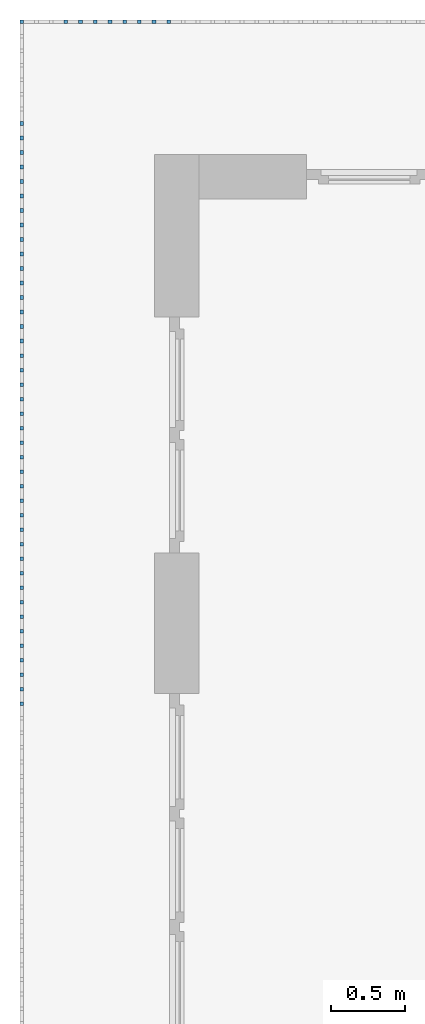
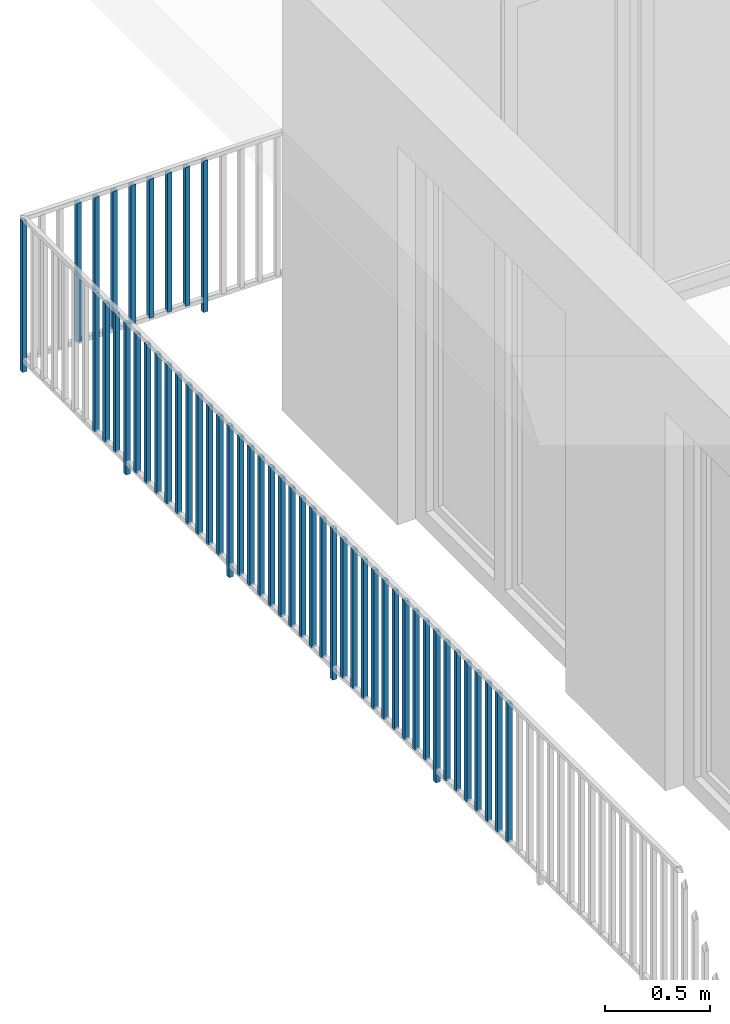
# One storey, part 47 of 54: 50 building element parts, 1 element without a shape of its own.
"""IFC4 building model written with IfcOpenShell, lengths in metres."""

from ifc_helpers import new_model, entity, si_unit, converted_unit, derived_unit, direction, frame, origin_with_axes, place, context, subcontext, project, spatial, polygons, material, type_object, element, aggregate, save


model = new_model("IFC4")

# Units and contexts
model_context = context("Model", 3, precision=1e-05, world=origin_with_axes(), true_north=direction((0.0, 1.0)))
body_context = subcontext(model_context, "Body", "Model", "MODEL_VIEW")
ifc_project = project(units=[si_unit("LENGTHUNIT", "METRE"), si_unit("AREAUNIT", "SQUARE_METRE"), si_unit("VOLUMEUNIT", "CUBIC_METRE"), converted_unit("PLANEANGLEUNIT", "DEGREE", entity("IfcPlaneAngleMeasure", 0.0174532925199), si_unit("PLANEANGLEUNIT", "RADIAN"), dimensions=[0, 0, 0, 0, 0, 0, 0]), converted_unit("TIMEUNIT", "Year", entity("IfcTimeMeasure", 31556926.0), si_unit("TIMEUNIT", "SECOND"), dimensions=[0, 0, 1, 0, 0, 0, 0]), si_unit("MASSUNIT", "GRAM", prefix="KILO"), si_unit("THERMODYNAMICTEMPERATUREUNIT", "DEGREE_CELSIUS"), si_unit("LUMINOUSINTENSITYUNIT", "LUMEN"), si_unit("ENERGYUNIT", "JOULE", prefix="MEGA"), derived_unit("THERMALCONDUCTANCEUNIT", [(si_unit("POWERUNIT", "WATT"), 1), (si_unit("LENGTHUNIT", "METRE"), -1), (si_unit("THERMODYNAMICTEMPERATUREUNIT", "KELVIN"), -1)]), derived_unit("SPECIFICHEATCAPACITYUNIT", [(si_unit("ENERGYUNIT", "JOULE"), 1), (si_unit("MASSUNIT", "GRAM", prefix="KILO"), -1), (si_unit("THERMODYNAMICTEMPERATUREUNIT", "KELVIN"), -1)]), derived_unit("MASSDENSITYUNIT", [(si_unit("MASSUNIT", "GRAM", prefix="KILO"), 1), (si_unit("VOLUMEUNIT", "CUBIC_METRE"), -1)])], contexts=[model_context])

# Site, building, storey, space
site_placement = place(None, origin_with_axes())
site = spatial("IfcSite", under=ifc_project, at=site_placement, CompositionType="ELEMENT")
building_placement = place(site_placement, origin_with_axes())
building = spatial("IfcBuilding", under=site, at=building_placement, CompositionType="ELEMENT")
storey_placement = place(building_placement, frame((0.0, 0.0, 6.29), z_axis=(0.0, 0.0, 1.0), x_axis=(1.0, 0.0, 0.0)))
storey = spatial("IfcBuildingStorey", under=building, at=storey_placement, Name="2. Geschoss", CompositionType="ELEMENT", Elevation=6.29)
space_placement = place(storey_placement, frame((10.2378006196, 9.82118769833, 0.0), z_axis=(0.0, 0.0, 1.0), x_axis=(-1.0, 0.0, 0.0)))
space = spatial("IfcSpace", under=storey, at=space_placement, CompositionType="ELEMENT", PredefinedType="EXTERNAL")

# Railing, building element parts
railing_type = type_object("IfcRailingType", PredefinedType="NOTDEFINED")
railing_placement = place(space_placement, frame((0.0, -7.06315681498e-08, 0.0), z_axis=(0.0, 0.0, 1.0), x_axis=(-1.0, 0.0, 0.0)))
railing = element("IfcRailing", 1, at=railing_placement, inside=space, type_object=railing_type, PredefinedType="NOTDEFINED")
ifc_material = material()
building_element_part_1_placement = place(railing_placement, origin_with_axes())
building_element_part_1 = element("IfcBuildingElementPart", 2, at=building_element_part_1_placement, material=ifc_material, PredefinedType="NOTDEFINED", context=body_context, shape_type="Tessellation", body=[
    polygons([(-22.8925, 0.0125, 0.0), (-22.8925, -0.0125, 0.0), (-22.8925, -0.0125, 0.88), (-22.8925, 0.0125, 0.88), (-22.8675, 0.0125, 0.0), (-22.8675, -0.0125, 0.0), (-22.8675, -0.0125, 0.88), (-22.8675, 0.0125, 0.88)], [[[1, 2, 3, 4]], [[1, 5, 6, 2]], [[2, 6, 7, 3]], [[4, 3, 7, 8]], [[5, 1, 4, 8]], [[6, 5, 8, 7]]], closed=True),
])
building_element_part_2_placement = place(railing_placement, origin_with_axes())
building_element_part_2 = element("IfcBuildingElementPart", 3, at=building_element_part_2_placement, material=ifc_material, PredefinedType="NOTDEFINED", context=body_context, shape_type="Tessellation", body=[
    polygons([(-21.8977173913, 0.0125, 0.0), (-21.8977173913, -0.0125, 0.0), (-21.8977173913, -0.0125, 0.88), (-21.8977173913, 0.0125, 0.88), (-21.8727173913, 0.0125, 0.0), (-21.8727173913, -0.0125, 0.0), (-21.8727173913, -0.0125, 0.88), (-21.8727173913, 0.0125, 0.88)], [[[1, 2, 3, 4]], [[1, 5, 6, 2]], [[2, 6, 7, 3]], [[4, 3, 7, 8]], [[5, 1, 4, 8]], [[6, 5, 8, 7]]], closed=True),
])
building_element_part_3_placement = place(railing_placement, origin_with_axes())
building_element_part_3 = element("IfcBuildingElementPart", 4, at=building_element_part_3_placement, material=ifc_material, PredefinedType="NOTDEFINED", context=body_context, shape_type="Tessellation", body=[
    polygons([(-21.9971956522, 0.0125, 0.07), (-21.9971956522, -0.0125, 0.07), (-21.9971956522, -0.0125, 0.8775), (-21.9971956522, 0.0125, 0.8775), (-21.9721956522, 0.0125, 0.07), (-21.9721956522, -0.0125, 0.07), (-21.9721956522, -0.0125, 0.8775), (-21.9721956522, 0.0125, 0.8775)], [[[1, 2, 3, 4]], [[1, 5, 6, 2]], [[2, 6, 7, 3]], [[4, 3, 7, 8]], [[5, 1, 4, 8]], [[6, 5, 8, 7]]], closed=True),
])
building_element_part_4_placement = place(railing_placement, origin_with_axes())
building_element_part_4 = element("IfcBuildingElementPart", 5, at=building_element_part_4_placement, material=ifc_material, PredefinedType="NOTDEFINED", context=body_context, shape_type="Tessellation", body=[
    polygons([(-22.096673913, 0.0125, 0.07), (-22.096673913, -0.0125, 0.07), (-22.096673913, -0.0125, 0.8775), (-22.096673913, 0.0125, 0.8775), (-22.071673913, 0.0125, 0.07), (-22.071673913, -0.0125, 0.07), (-22.071673913, -0.0125, 0.8775), (-22.071673913, 0.0125, 0.8775)], [[[1, 2, 3, 4]], [[1, 5, 6, 2]], [[2, 6, 7, 3]], [[4, 3, 7, 8]], [[5, 1, 4, 8]], [[6, 5, 8, 7]]], closed=True),
])
building_element_part_5_placement = place(railing_placement, origin_with_axes())
building_element_part_5 = element("IfcBuildingElementPart", 6, at=building_element_part_5_placement, material=ifc_material, PredefinedType="NOTDEFINED", context=body_context, shape_type="Tessellation", body=[
    polygons([(-22.1961521739, 0.0125, 0.07), (-22.1961521739, -0.0125, 0.07), (-22.1961521739, -0.0125, 0.8775), (-22.1961521739, 0.0125, 0.8775), (-22.1711521739, 0.0125, 0.07), (-22.1711521739, -0.0125, 0.07), (-22.1711521739, -0.0125, 0.8775), (-22.1711521739, 0.0125, 0.8775)], [[[1, 2, 3, 4]], [[1, 5, 6, 2]], [[2, 6, 7, 3]], [[4, 3, 7, 8]], [[5, 1, 4, 8]], [[6, 5, 8, 7]]], closed=True),
])
building_element_part_6_placement = place(railing_placement, origin_with_axes())
building_element_part_6 = element("IfcBuildingElementPart", 7, at=building_element_part_6_placement, material=ifc_material, PredefinedType="NOTDEFINED", context=body_context, shape_type="Tessellation", body=[
    polygons([(-22.2956304348, 0.0125, 0.07), (-22.2956304348, -0.0125, 0.07), (-22.2956304348, -0.0125, 0.8775), (-22.2956304348, 0.0125, 0.8775), (-22.2706304348, 0.0125, 0.07), (-22.2706304348, -0.0125, 0.07), (-22.2706304348, -0.0125, 0.8775), (-22.2706304348, 0.0125, 0.8775)], [[[1, 2, 3, 4]], [[1, 5, 6, 2]], [[2, 6, 7, 3]], [[4, 3, 7, 8]], [[5, 1, 4, 8]], [[6, 5, 8, 7]]], closed=True),
])
building_element_part_7_placement = place(railing_placement, origin_with_axes())
building_element_part_7 = element("IfcBuildingElementPart", 8, at=building_element_part_7_placement, material=ifc_material, PredefinedType="NOTDEFINED", context=body_context, shape_type="Tessellation", body=[
    polygons([(-22.3951086957, 0.0125, 0.07), (-22.3951086957, -0.0125, 0.07), (-22.3951086957, -0.0125, 0.8775), (-22.3951086957, 0.0125, 0.8775), (-22.3701086957, 0.0125, 0.07), (-22.3701086957, -0.0125, 0.07), (-22.3701086957, -0.0125, 0.8775), (-22.3701086957, 0.0125, 0.8775)], [[[1, 2, 3, 4]], [[1, 5, 6, 2]], [[2, 6, 7, 3]], [[4, 3, 7, 8]], [[5, 1, 4, 8]], [[6, 5, 8, 7]]], closed=True),
])
building_element_part_8_placement = place(railing_placement, origin_with_axes())
building_element_part_8 = element("IfcBuildingElementPart", 9, at=building_element_part_8_placement, material=ifc_material, PredefinedType="NOTDEFINED", context=body_context, shape_type="Tessellation", body=[
    polygons([(-22.4945869565, 0.0125, 0.07), (-22.4945869565, -0.0125, 0.07), (-22.4945869565, -0.0125, 0.8775), (-22.4945869565, 0.0125, 0.8775), (-22.4695869565, 0.0125, 0.07), (-22.4695869565, -0.0125, 0.07), (-22.4695869565, -0.0125, 0.8775), (-22.4695869565, 0.0125, 0.8775)], [[[1, 2, 3, 4]], [[1, 5, 6, 2]], [[2, 6, 7, 3]], [[4, 3, 7, 8]], [[5, 1, 4, 8]], [[6, 5, 8, 7]]], closed=True),
])
building_element_part_9_placement = place(railing_placement, origin_with_axes())
building_element_part_9 = element("IfcBuildingElementPart", 10, at=building_element_part_9_placement, material=ifc_material, PredefinedType="NOTDEFINED", context=body_context, shape_type="Tessellation", body=[
    polygons([(-22.5940652174, 0.0125, 0.07), (-22.5940652174, -0.0125, 0.07), (-22.5940652174, -0.0125, 0.8775), (-22.5940652174, 0.0125, 0.8775), (-22.5690652174, 0.0125, 0.07), (-22.5690652174, -0.0125, 0.07), (-22.5690652174, -0.0125, 0.8775), (-22.5690652174, 0.0125, 0.8775)], [[[1, 2, 3, 4]], [[1, 5, 6, 2]], [[2, 6, 7, 3]], [[4, 3, 7, 8]], [[5, 1, 4, 8]], [[6, 5, 8, 7]]], closed=True),
])
building_element_part_10_placement = place(railing_placement, origin_with_axes())
building_element_part_10 = element("IfcBuildingElementPart", 11, at=building_element_part_10_placement, material=ifc_material, PredefinedType="NOTDEFINED", context=body_context, shape_type="Tessellation", body=[
    polygons([(-22.8925, -0.700833333333, 0.07), (-22.8675, -0.700833333333, 0.07), (-22.8675, -0.700833333333, 0.8775), (-22.8925, -0.700833333333, 0.8775), (-22.8925, -0.675833333333, 0.07), (-22.8675, -0.675833333333, 0.07), (-22.8675, -0.675833333333, 0.8775), (-22.8925, -0.675833333333, 0.8775)], [[[1, 2, 3, 4]], [[1, 5, 6, 2]], [[2, 6, 7, 3]], [[4, 3, 7, 8]], [[5, 1, 4, 8]], [[6, 5, 8, 7]]], closed=True),
])
building_element_part_11_placement = place(railing_placement, origin_with_axes())
building_element_part_11 = element("IfcBuildingElementPart", 12, at=building_element_part_11_placement, material=ifc_material, PredefinedType="NOTDEFINED", context=body_context, shape_type="Tessellation", body=[
    polygons([(-22.8925, -0.799166666667, 0.07), (-22.8675, -0.799166666667, 0.07), (-22.8675, -0.799166666667, 0.8775), (-22.8925, -0.799166666667, 0.8775), (-22.8925, -0.774166666667, 0.07), (-22.8675, -0.774166666667, 0.07), (-22.8675, -0.774166666667, 0.8775), (-22.8925, -0.774166666667, 0.8775)], [[[1, 2, 3, 4]], [[1, 5, 6, 2]], [[2, 6, 7, 3]], [[4, 3, 7, 8]], [[5, 1, 4, 8]], [[6, 5, 8, 7]]], closed=True),
])
building_element_part_12_placement = place(railing_placement, origin_with_axes())
building_element_part_12 = element("IfcBuildingElementPart", 13, at=building_element_part_12_placement, material=ifc_material, PredefinedType="NOTDEFINED", context=body_context, shape_type="Tessellation", body=[
    polygons([(-22.8925, -0.8975, 0.07), (-22.8675, -0.8975, 0.07), (-22.8675, -0.8975, 0.8775), (-22.8925, -0.8975, 0.8775), (-22.8925, -0.8725, 0.07), (-22.8675, -0.8725, 0.07), (-22.8675, -0.8725, 0.8775), (-22.8925, -0.8725, 0.8775)], [[[1, 2, 3, 4]], [[1, 5, 6, 2]], [[2, 6, 7, 3]], [[4, 3, 7, 8]], [[5, 1, 4, 8]], [[6, 5, 8, 7]]], closed=True),
])
building_element_part_13_placement = place(railing_placement, origin_with_axes())
building_element_part_13 = element("IfcBuildingElementPart", 14, at=building_element_part_13_placement, material=ifc_material, PredefinedType="NOTDEFINED", context=body_context, shape_type="Tessellation", body=[
    polygons([(-22.8925, -0.995833333333, 0.0), (-22.8675, -0.995833333333, 0.0), (-22.8675, -0.995833333333, 0.88), (-22.8925, -0.995833333333, 0.88), (-22.8925, -0.970833333333, 0.0), (-22.8675, -0.970833333333, 0.0), (-22.8675, -0.970833333333, 0.88), (-22.8925, -0.970833333333, 0.88)], [[[1, 2, 3, 4]], [[1, 5, 6, 2]], [[2, 6, 7, 3]], [[4, 3, 7, 8]], [[5, 1, 4, 8]], [[6, 5, 8, 7]]], closed=True),
])
building_element_part_14_placement = place(railing_placement, origin_with_axes())
building_element_part_14 = element("IfcBuildingElementPart", 15, at=building_element_part_14_placement, material=ifc_material, PredefinedType="NOTDEFINED", context=body_context, shape_type="Tessellation", body=[
    polygons([(-22.8925, -1.09416666667, 0.07), (-22.8675, -1.09416666667, 0.07), (-22.8675, -1.09416666667, 0.8775), (-22.8925, -1.09416666667, 0.8775), (-22.8925, -1.06916666667, 0.07), (-22.8675, -1.06916666667, 0.07), (-22.8675, -1.06916666667, 0.8775), (-22.8925, -1.06916666667, 0.8775)], [[[1, 2, 3, 4]], [[1, 5, 6, 2]], [[2, 6, 7, 3]], [[4, 3, 7, 8]], [[5, 1, 4, 8]], [[6, 5, 8, 7]]], closed=True),
])
building_element_part_15_placement = place(railing_placement, origin_with_axes())
building_element_part_15 = element("IfcBuildingElementPart", 16, at=building_element_part_15_placement, material=ifc_material, PredefinedType="NOTDEFINED", context=body_context, shape_type="Tessellation", body=[
    polygons([(-22.8925, -1.1925, 0.07), (-22.8675, -1.1925, 0.07), (-22.8675, -1.1925, 0.8775), (-22.8925, -1.1925, 0.8775), (-22.8925, -1.1675, 0.07), (-22.8675, -1.1675, 0.07), (-22.8675, -1.1675, 0.8775), (-22.8925, -1.1675, 0.8775)], [[[1, 2, 3, 4]], [[1, 5, 6, 2]], [[2, 6, 7, 3]], [[4, 3, 7, 8]], [[5, 1, 4, 8]], [[6, 5, 8, 7]]], closed=True),
])
building_element_part_16_placement = place(railing_placement, origin_with_axes())
building_element_part_16 = element("IfcBuildingElementPart", 17, at=building_element_part_16_placement, material=ifc_material, PredefinedType="NOTDEFINED", context=body_context, shape_type="Tessellation", body=[
    polygons([(-22.8925, -1.29083333333, 0.07), (-22.8675, -1.29083333333, 0.07), (-22.8675, -1.29083333333, 0.8775), (-22.8925, -1.29083333333, 0.8775), (-22.8925, -1.26583333333, 0.07), (-22.8675, -1.26583333333, 0.07), (-22.8675, -1.26583333333, 0.8775), (-22.8925, -1.26583333333, 0.8775)], [[[1, 2, 3, 4]], [[1, 5, 6, 2]], [[2, 6, 7, 3]], [[4, 3, 7, 8]], [[5, 1, 4, 8]], [[6, 5, 8, 7]]], closed=True),
])
building_element_part_17_placement = place(railing_placement, origin_with_axes())
building_element_part_17 = element("IfcBuildingElementPart", 18, at=building_element_part_17_placement, material=ifc_material, PredefinedType="NOTDEFINED", context=body_context, shape_type="Tessellation", body=[
    polygons([(-22.8925, -1.38916666667, 0.07), (-22.8675, -1.38916666667, 0.07), (-22.8675, -1.38916666667, 0.8775), (-22.8925, -1.38916666667, 0.8775), (-22.8925, -1.36416666667, 0.07), (-22.8675, -1.36416666667, 0.07), (-22.8675, -1.36416666667, 0.8775), (-22.8925, -1.36416666667, 0.8775)], [[[1, 2, 3, 4]], [[1, 5, 6, 2]], [[2, 6, 7, 3]], [[4, 3, 7, 8]], [[5, 1, 4, 8]], [[6, 5, 8, 7]]], closed=True),
])
building_element_part_18_placement = place(railing_placement, origin_with_axes())
building_element_part_18 = element("IfcBuildingElementPart", 19, at=building_element_part_18_placement, material=ifc_material, PredefinedType="NOTDEFINED", context=body_context, shape_type="Tessellation", body=[
    polygons([(-22.8925, -1.4875, 0.07), (-22.8675, -1.4875, 0.07), (-22.8675, -1.4875, 0.8775), (-22.8925, -1.4875, 0.8775), (-22.8925, -1.4625, 0.07), (-22.8675, -1.4625, 0.07), (-22.8675, -1.4625, 0.8775), (-22.8925, -1.4625, 0.8775)], [[[1, 2, 3, 4]], [[1, 5, 6, 2]], [[2, 6, 7, 3]], [[4, 3, 7, 8]], [[5, 1, 4, 8]], [[6, 5, 8, 7]]], closed=True),
])
building_element_part_19_placement = place(railing_placement, origin_with_axes())
building_element_part_19 = element("IfcBuildingElementPart", 20, at=building_element_part_19_placement, material=ifc_material, PredefinedType="NOTDEFINED", context=body_context, shape_type="Tessellation", body=[
    polygons([(-22.8925, -1.58583333333, 0.07), (-22.8675, -1.58583333333, 0.07), (-22.8675, -1.58583333333, 0.8775), (-22.8925, -1.58583333333, 0.8775), (-22.8925, -1.56083333333, 0.07), (-22.8675, -1.56083333333, 0.07), (-22.8675, -1.56083333333, 0.8775), (-22.8925, -1.56083333333, 0.8775)], [[[1, 2, 3, 4]], [[1, 5, 6, 2]], [[2, 6, 7, 3]], [[4, 3, 7, 8]], [[5, 1, 4, 8]], [[6, 5, 8, 7]]], closed=True),
])
building_element_part_20_placement = place(railing_placement, origin_with_axes())
building_element_part_20 = element("IfcBuildingElementPart", 21, at=building_element_part_20_placement, material=ifc_material, PredefinedType="NOTDEFINED", context=body_context, shape_type="Tessellation", body=[
    polygons([(-22.8925, -1.68416666667, 0.07), (-22.8675, -1.68416666667, 0.07), (-22.8675, -1.68416666667, 0.8775), (-22.8925, -1.68416666667, 0.8775), (-22.8925, -1.65916666667, 0.07), (-22.8675, -1.65916666667, 0.07), (-22.8675, -1.65916666667, 0.8775), (-22.8925, -1.65916666667, 0.8775)], [[[1, 2, 3, 4]], [[1, 5, 6, 2]], [[2, 6, 7, 3]], [[4, 3, 7, 8]], [[5, 1, 4, 8]], [[6, 5, 8, 7]]], closed=True),
])
building_element_part_21_placement = place(railing_placement, origin_with_axes())
building_element_part_21 = element("IfcBuildingElementPart", 22, at=building_element_part_21_placement, material=ifc_material, PredefinedType="NOTDEFINED", context=body_context, shape_type="Tessellation", body=[
    polygons([(-22.8925, -1.7825, 0.07), (-22.8675, -1.7825, 0.07), (-22.8675, -1.7825, 0.8775), (-22.8925, -1.7825, 0.8775), (-22.8925, -1.7575, 0.07), (-22.8675, -1.7575, 0.07), (-22.8675, -1.7575, 0.8775), (-22.8925, -1.7575, 0.8775)], [[[1, 2, 3, 4]], [[1, 5, 6, 2]], [[2, 6, 7, 3]], [[4, 3, 7, 8]], [[5, 1, 4, 8]], [[6, 5, 8, 7]]], closed=True),
])
building_element_part_22_placement = place(railing_placement, origin_with_axes())
building_element_part_22 = element("IfcBuildingElementPart", 23, at=building_element_part_22_placement, material=ifc_material, PredefinedType="NOTDEFINED", context=body_context, shape_type="Tessellation", body=[
    polygons([(-22.8925, -1.88083333333, 0.07), (-22.8675, -1.88083333333, 0.07), (-22.8675, -1.88083333333, 0.8775), (-22.8925, -1.88083333333, 0.8775), (-22.8925, -1.85583333333, 0.07), (-22.8675, -1.85583333333, 0.07), (-22.8675, -1.85583333333, 0.8775), (-22.8925, -1.85583333333, 0.8775)], [[[1, 2, 3, 4]], [[1, 5, 6, 2]], [[2, 6, 7, 3]], [[4, 3, 7, 8]], [[5, 1, 4, 8]], [[6, 5, 8, 7]]], closed=True),
])
building_element_part_23_placement = place(railing_placement, origin_with_axes())
building_element_part_23 = element("IfcBuildingElementPart", 24, at=building_element_part_23_placement, material=ifc_material, PredefinedType="NOTDEFINED", context=body_context, shape_type="Tessellation", body=[
    polygons([(-22.8925, -1.97916666667, 0.0), (-22.8675, -1.97916666667, 0.0), (-22.8675, -1.97916666667, 0.88), (-22.8925, -1.97916666667, 0.88), (-22.8925, -1.95416666667, 0.0), (-22.8675, -1.95416666667, 0.0), (-22.8675, -1.95416666667, 0.88), (-22.8925, -1.95416666667, 0.88)], [[[1, 2, 3, 4]], [[1, 5, 6, 2]], [[2, 6, 7, 3]], [[4, 3, 7, 8]], [[5, 1, 4, 8]], [[6, 5, 8, 7]]], closed=True),
])
building_element_part_24_placement = place(railing_placement, origin_with_axes())
building_element_part_24 = element("IfcBuildingElementPart", 25, at=building_element_part_24_placement, material=ifc_material, PredefinedType="NOTDEFINED", context=body_context, shape_type="Tessellation", body=[
    polygons([(-22.8925, -2.0775, 0.07), (-22.8675, -2.0775, 0.07), (-22.8675, -2.0775, 0.8775), (-22.8925, -2.0775, 0.8775), (-22.8925, -2.0525, 0.07), (-22.8675, -2.0525, 0.07), (-22.8675, -2.0525, 0.8775), (-22.8925, -2.0525, 0.8775)], [[[1, 2, 3, 4]], [[1, 5, 6, 2]], [[2, 6, 7, 3]], [[4, 3, 7, 8]], [[5, 1, 4, 8]], [[6, 5, 8, 7]]], closed=True),
])
building_element_part_25_placement = place(railing_placement, origin_with_axes())
building_element_part_25 = element("IfcBuildingElementPart", 26, at=building_element_part_25_placement, material=ifc_material, PredefinedType="NOTDEFINED", context=body_context, shape_type="Tessellation", body=[
    polygons([(-22.8925, -2.17583333333, 0.07), (-22.8675, -2.17583333333, 0.07), (-22.8675, -2.17583333333, 0.8775), (-22.8925, -2.17583333333, 0.8775), (-22.8925, -2.15083333333, 0.07), (-22.8675, -2.15083333333, 0.07), (-22.8675, -2.15083333333, 0.8775), (-22.8925, -2.15083333333, 0.8775)], [[[1, 2, 3, 4]], [[1, 5, 6, 2]], [[2, 6, 7, 3]], [[4, 3, 7, 8]], [[5, 1, 4, 8]], [[6, 5, 8, 7]]], closed=True),
])
building_element_part_26_placement = place(railing_placement, origin_with_axes())
building_element_part_26 = element("IfcBuildingElementPart", 27, at=building_element_part_26_placement, material=ifc_material, PredefinedType="NOTDEFINED", context=body_context, shape_type="Tessellation", body=[
    polygons([(-22.8925, -2.27416666667, 0.07), (-22.8675, -2.27416666667, 0.07), (-22.8675, -2.27416666667, 0.8775), (-22.8925, -2.27416666667, 0.8775), (-22.8925, -2.24916666667, 0.07), (-22.8675, -2.24916666667, 0.07), (-22.8675, -2.24916666667, 0.8775), (-22.8925, -2.24916666667, 0.8775)], [[[1, 2, 3, 4]], [[1, 5, 6, 2]], [[2, 6, 7, 3]], [[4, 3, 7, 8]], [[5, 1, 4, 8]], [[6, 5, 8, 7]]], closed=True),
])
building_element_part_27_placement = place(railing_placement, origin_with_axes())
building_element_part_27 = element("IfcBuildingElementPart", 28, at=building_element_part_27_placement, material=ifc_material, PredefinedType="NOTDEFINED", context=body_context, shape_type="Tessellation", body=[
    polygons([(-22.8925, -2.3725, 0.07), (-22.8675, -2.3725, 0.07), (-22.8675, -2.3725, 0.8775), (-22.8925, -2.3725, 0.8775), (-22.8925, -2.3475, 0.07), (-22.8675, -2.3475, 0.07), (-22.8675, -2.3475, 0.8775), (-22.8925, -2.3475, 0.8775)], [[[1, 2, 3, 4]], [[1, 5, 6, 2]], [[2, 6, 7, 3]], [[4, 3, 7, 8]], [[5, 1, 4, 8]], [[6, 5, 8, 7]]], closed=True),
])
building_element_part_28_placement = place(railing_placement, origin_with_axes())
building_element_part_28 = element("IfcBuildingElementPart", 29, at=building_element_part_28_placement, material=ifc_material, PredefinedType="NOTDEFINED", context=body_context, shape_type="Tessellation", body=[
    polygons([(-22.8925, -2.47083333333, 0.07), (-22.8675, -2.47083333333, 0.07), (-22.8675, -2.47083333333, 0.8775), (-22.8925, -2.47083333333, 0.8775), (-22.8925, -2.44583333333, 0.07), (-22.8675, -2.44583333333, 0.07), (-22.8675, -2.44583333333, 0.8775), (-22.8925, -2.44583333333, 0.8775)], [[[1, 2, 3, 4]], [[1, 5, 6, 2]], [[2, 6, 7, 3]], [[4, 3, 7, 8]], [[5, 1, 4, 8]], [[6, 5, 8, 7]]], closed=True),
])
building_element_part_29_placement = place(railing_placement, origin_with_axes())
building_element_part_29 = element("IfcBuildingElementPart", 30, at=building_element_part_29_placement, material=ifc_material, PredefinedType="NOTDEFINED", context=body_context, shape_type="Tessellation", body=[
    polygons([(-22.8925, -2.56916666667, 0.07), (-22.8675, -2.56916666667, 0.07), (-22.8675, -2.56916666667, 0.8775), (-22.8925, -2.56916666667, 0.8775), (-22.8925, -2.54416666667, 0.07), (-22.8675, -2.54416666667, 0.07), (-22.8675, -2.54416666667, 0.8775), (-22.8925, -2.54416666667, 0.8775)], [[[1, 2, 3, 4]], [[1, 5, 6, 2]], [[2, 6, 7, 3]], [[4, 3, 7, 8]], [[5, 1, 4, 8]], [[6, 5, 8, 7]]], closed=True),
])
building_element_part_30_placement = place(railing_placement, origin_with_axes())
building_element_part_30 = element("IfcBuildingElementPart", 31, at=building_element_part_30_placement, material=ifc_material, PredefinedType="NOTDEFINED", context=body_context, shape_type="Tessellation", body=[
    polygons([(-22.8925, -2.6675, 0.07), (-22.8675, -2.6675, 0.07), (-22.8675, -2.6675, 0.8775), (-22.8925, -2.6675, 0.8775), (-22.8925, -2.6425, 0.07), (-22.8675, -2.6425, 0.07), (-22.8675, -2.6425, 0.8775), (-22.8925, -2.6425, 0.8775)], [[[1, 2, 3, 4]], [[1, 5, 6, 2]], [[2, 6, 7, 3]], [[4, 3, 7, 8]], [[5, 1, 4, 8]], [[6, 5, 8, 7]]], closed=True),
])
building_element_part_31_placement = place(railing_placement, origin_with_axes())
building_element_part_31 = element("IfcBuildingElementPart", 32, at=building_element_part_31_placement, material=ifc_material, PredefinedType="NOTDEFINED", context=body_context, shape_type="Tessellation", body=[
    polygons([(-22.8925, -2.76583333333, 0.07), (-22.8675, -2.76583333333, 0.07), (-22.8675, -2.76583333333, 0.8775), (-22.8925, -2.76583333333, 0.8775), (-22.8925, -2.74083333333, 0.07), (-22.8675, -2.74083333333, 0.07), (-22.8675, -2.74083333333, 0.8775), (-22.8925, -2.74083333333, 0.8775)], [[[1, 2, 3, 4]], [[1, 5, 6, 2]], [[2, 6, 7, 3]], [[4, 3, 7, 8]], [[5, 1, 4, 8]], [[6, 5, 8, 7]]], closed=True),
])
building_element_part_32_placement = place(railing_placement, origin_with_axes())
building_element_part_32 = element("IfcBuildingElementPart", 33, at=building_element_part_32_placement, material=ifc_material, PredefinedType="NOTDEFINED", context=body_context, shape_type="Tessellation", body=[
    polygons([(-22.8925, -2.86416666667, 0.07), (-22.8675, -2.86416666667, 0.07), (-22.8675, -2.86416666667, 0.8775), (-22.8925, -2.86416666667, 0.8775), (-22.8925, -2.83916666667, 0.07), (-22.8675, -2.83916666667, 0.07), (-22.8675, -2.83916666667, 0.8775), (-22.8925, -2.83916666667, 0.8775)], [[[1, 2, 3, 4]], [[1, 5, 6, 2]], [[2, 6, 7, 3]], [[4, 3, 7, 8]], [[5, 1, 4, 8]], [[6, 5, 8, 7]]], closed=True),
])
building_element_part_33_placement = place(railing_placement, origin_with_axes())
building_element_part_33 = element("IfcBuildingElementPart", 34, at=building_element_part_33_placement, material=ifc_material, PredefinedType="NOTDEFINED", context=body_context, shape_type="Tessellation", body=[
    polygons([(-22.8925, -2.9625, 0.0), (-22.8675, -2.9625, 0.0), (-22.8675, -2.9625, 0.88), (-22.8925, -2.9625, 0.88), (-22.8925, -2.9375, 0.0), (-22.8675, -2.9375, 0.0), (-22.8675, -2.9375, 0.88), (-22.8925, -2.9375, 0.88)], [[[1, 2, 3, 4]], [[1, 5, 6, 2]], [[2, 6, 7, 3]], [[4, 3, 7, 8]], [[5, 1, 4, 8]], [[6, 5, 8, 7]]], closed=True),
])
building_element_part_34_placement = place(railing_placement, origin_with_axes())
building_element_part_34 = element("IfcBuildingElementPart", 35, at=building_element_part_34_placement, material=ifc_material, PredefinedType="NOTDEFINED", context=body_context, shape_type="Tessellation", body=[
    polygons([(-22.8925, -3.06083333333, 0.07), (-22.8675, -3.06083333333, 0.07), (-22.8675, -3.06083333333, 0.8775), (-22.8925, -3.06083333333, 0.8775), (-22.8925, -3.03583333333, 0.07), (-22.8675, -3.03583333333, 0.07), (-22.8675, -3.03583333333, 0.8775), (-22.8925, -3.03583333333, 0.8775)], [[[1, 2, 3, 4]], [[1, 5, 6, 2]], [[2, 6, 7, 3]], [[4, 3, 7, 8]], [[5, 1, 4, 8]], [[6, 5, 8, 7]]], closed=True),
])
building_element_part_35_placement = place(railing_placement, origin_with_axes())
building_element_part_35 = element("IfcBuildingElementPart", 36, at=building_element_part_35_placement, material=ifc_material, PredefinedType="NOTDEFINED", context=body_context, shape_type="Tessellation", body=[
    polygons([(-22.8925, -3.15916666667, 0.07), (-22.8675, -3.15916666667, 0.07), (-22.8675, -3.15916666667, 0.8775), (-22.8925, -3.15916666667, 0.8775), (-22.8925, -3.13416666667, 0.07), (-22.8675, -3.13416666667, 0.07), (-22.8675, -3.13416666667, 0.8775), (-22.8925, -3.13416666667, 0.8775)], [[[1, 2, 3, 4]], [[1, 5, 6, 2]], [[2, 6, 7, 3]], [[4, 3, 7, 8]], [[5, 1, 4, 8]], [[6, 5, 8, 7]]], closed=True),
])
building_element_part_36_placement = place(railing_placement, origin_with_axes())
building_element_part_36 = element("IfcBuildingElementPart", 37, at=building_element_part_36_placement, material=ifc_material, PredefinedType="NOTDEFINED", context=body_context, shape_type="Tessellation", body=[
    polygons([(-22.8925, -3.2575, 0.07), (-22.8675, -3.2575, 0.07), (-22.8675, -3.2575, 0.8775), (-22.8925, -3.2575, 0.8775), (-22.8925, -3.2325, 0.07), (-22.8675, -3.2325, 0.07), (-22.8675, -3.2325, 0.8775), (-22.8925, -3.2325, 0.8775)], [[[1, 2, 3, 4]], [[1, 5, 6, 2]], [[2, 6, 7, 3]], [[4, 3, 7, 8]], [[5, 1, 4, 8]], [[6, 5, 8, 7]]], closed=True),
])
building_element_part_37_placement = place(railing_placement, origin_with_axes())
building_element_part_37 = element("IfcBuildingElementPart", 38, at=building_element_part_37_placement, material=ifc_material, PredefinedType="NOTDEFINED", context=body_context, shape_type="Tessellation", body=[
    polygons([(-22.8925, -3.35583333333, 0.07), (-22.8675, -3.35583333333, 0.07), (-22.8675, -3.35583333333, 0.8775), (-22.8925, -3.35583333333, 0.8775), (-22.8925, -3.33083333333, 0.07), (-22.8675, -3.33083333333, 0.07), (-22.8675, -3.33083333333, 0.8775), (-22.8925, -3.33083333333, 0.8775)], [[[1, 2, 3, 4]], [[1, 5, 6, 2]], [[2, 6, 7, 3]], [[4, 3, 7, 8]], [[5, 1, 4, 8]], [[6, 5, 8, 7]]], closed=True),
])
building_element_part_38_placement = place(railing_placement, origin_with_axes())
building_element_part_38 = element("IfcBuildingElementPart", 39, at=building_element_part_38_placement, material=ifc_material, PredefinedType="NOTDEFINED", context=body_context, shape_type="Tessellation", body=[
    polygons([(-22.8925, -3.45416666667, 0.07), (-22.8675, -3.45416666667, 0.07), (-22.8675, -3.45416666667, 0.8775), (-22.8925, -3.45416666667, 0.8775), (-22.8925, -3.42916666667, 0.07), (-22.8675, -3.42916666667, 0.07), (-22.8675, -3.42916666667, 0.8775), (-22.8925, -3.42916666667, 0.8775)], [[[1, 2, 3, 4]], [[1, 5, 6, 2]], [[2, 6, 7, 3]], [[4, 3, 7, 8]], [[5, 1, 4, 8]], [[6, 5, 8, 7]]], closed=True),
])
building_element_part_39_placement = place(railing_placement, origin_with_axes())
building_element_part_39 = element("IfcBuildingElementPart", 40, at=building_element_part_39_placement, material=ifc_material, PredefinedType="NOTDEFINED", context=body_context, shape_type="Tessellation", body=[
    polygons([(-22.8925, -3.5525, 0.07), (-22.8675, -3.5525, 0.07), (-22.8675, -3.5525, 0.8775), (-22.8925, -3.5525, 0.8775), (-22.8925, -3.5275, 0.07), (-22.8675, -3.5275, 0.07), (-22.8675, -3.5275, 0.8775), (-22.8925, -3.5275, 0.8775)], [[[1, 2, 3, 4]], [[1, 5, 6, 2]], [[2, 6, 7, 3]], [[4, 3, 7, 8]], [[5, 1, 4, 8]], [[6, 5, 8, 7]]], closed=True),
])
building_element_part_40_placement = place(railing_placement, origin_with_axes())
building_element_part_40 = element("IfcBuildingElementPart", 41, at=building_element_part_40_placement, material=ifc_material, PredefinedType="NOTDEFINED", context=body_context, shape_type="Tessellation", body=[
    polygons([(-22.8925, -3.65083333333, 0.07), (-22.8675, -3.65083333333, 0.07), (-22.8675, -3.65083333333, 0.8775), (-22.8925, -3.65083333333, 0.8775), (-22.8925, -3.62583333333, 0.07), (-22.8675, -3.62583333333, 0.07), (-22.8675, -3.62583333333, 0.8775), (-22.8925, -3.62583333333, 0.8775)], [[[1, 2, 3, 4]], [[1, 5, 6, 2]], [[2, 6, 7, 3]], [[4, 3, 7, 8]], [[5, 1, 4, 8]], [[6, 5, 8, 7]]], closed=True),
])
building_element_part_41_placement = place(railing_placement, origin_with_axes())
building_element_part_41 = element("IfcBuildingElementPart", 42, at=building_element_part_41_placement, material=ifc_material, PredefinedType="NOTDEFINED", context=body_context, shape_type="Tessellation", body=[
    polygons([(-22.8925, -3.74916666667, 0.07), (-22.8675, -3.74916666667, 0.07), (-22.8675, -3.74916666667, 0.8775), (-22.8925, -3.74916666667, 0.8775), (-22.8925, -3.72416666667, 0.07), (-22.8675, -3.72416666667, 0.07), (-22.8675, -3.72416666667, 0.8775), (-22.8925, -3.72416666667, 0.8775)], [[[1, 2, 3, 4]], [[1, 5, 6, 2]], [[2, 6, 7, 3]], [[4, 3, 7, 8]], [[5, 1, 4, 8]], [[6, 5, 8, 7]]], closed=True),
])
building_element_part_42_placement = place(railing_placement, origin_with_axes())
building_element_part_42 = element("IfcBuildingElementPart", 43, at=building_element_part_42_placement, material=ifc_material, PredefinedType="NOTDEFINED", context=body_context, shape_type="Tessellation", body=[
    polygons([(-22.8925, -3.8475, 0.07), (-22.8675, -3.8475, 0.07), (-22.8675, -3.8475, 0.8775), (-22.8925, -3.8475, 0.8775), (-22.8925, -3.8225, 0.07), (-22.8675, -3.8225, 0.07), (-22.8675, -3.8225, 0.8775), (-22.8925, -3.8225, 0.8775)], [[[1, 2, 3, 4]], [[1, 5, 6, 2]], [[2, 6, 7, 3]], [[4, 3, 7, 8]], [[5, 1, 4, 8]], [[6, 5, 8, 7]]], closed=True),
])
building_element_part_43_placement = place(railing_placement, origin_with_axes())
building_element_part_43 = element("IfcBuildingElementPart", 44, at=building_element_part_43_placement, material=ifc_material, PredefinedType="NOTDEFINED", context=body_context, shape_type="Tessellation", body=[
    polygons([(-22.8925, -3.94583333333, 0.0), (-22.8675, -3.94583333333, 0.0), (-22.8675, -3.94583333333, 0.88), (-22.8925, -3.94583333333, 0.88), (-22.8925, -3.92083333333, 0.0), (-22.8675, -3.92083333333, 0.0), (-22.8675, -3.92083333333, 0.88), (-22.8925, -3.92083333333, 0.88)], [[[1, 2, 3, 4]], [[1, 5, 6, 2]], [[2, 6, 7, 3]], [[4, 3, 7, 8]], [[5, 1, 4, 8]], [[6, 5, 8, 7]]], closed=True),
])
building_element_part_44_placement = place(railing_placement, origin_with_axes())
building_element_part_44 = element("IfcBuildingElementPart", 45, at=building_element_part_44_placement, material=ifc_material, PredefinedType="NOTDEFINED", context=body_context, shape_type="Tessellation", body=[
    polygons([(-22.8925, -4.04416666667, 0.07), (-22.8675, -4.04416666667, 0.07), (-22.8675, -4.04416666667, 0.8775), (-22.8925, -4.04416666667, 0.8775), (-22.8925, -4.01916666667, 0.07), (-22.8675, -4.01916666667, 0.07), (-22.8675, -4.01916666667, 0.8775), (-22.8925, -4.01916666667, 0.8775)], [[[1, 2, 3, 4]], [[1, 5, 6, 2]], [[2, 6, 7, 3]], [[4, 3, 7, 8]], [[5, 1, 4, 8]], [[6, 5, 8, 7]]], closed=True),
])
building_element_part_45_placement = place(railing_placement, origin_with_axes())
building_element_part_45 = element("IfcBuildingElementPart", 46, at=building_element_part_45_placement, material=ifc_material, PredefinedType="NOTDEFINED", context=body_context, shape_type="Tessellation", body=[
    polygons([(-22.8925, -4.1425, 0.07), (-22.8675, -4.1425, 0.07), (-22.8675, -4.1425, 0.8775), (-22.8925, -4.1425, 0.8775), (-22.8925, -4.1175, 0.07), (-22.8675, -4.1175, 0.07), (-22.8675, -4.1175, 0.8775), (-22.8925, -4.1175, 0.8775)], [[[1, 2, 3, 4]], [[1, 5, 6, 2]], [[2, 6, 7, 3]], [[4, 3, 7, 8]], [[5, 1, 4, 8]], [[6, 5, 8, 7]]], closed=True),
])
building_element_part_46_placement = place(railing_placement, origin_with_axes())
building_element_part_46 = element("IfcBuildingElementPart", 47, at=building_element_part_46_placement, material=ifc_material, PredefinedType="NOTDEFINED", context=body_context, shape_type="Tessellation", body=[
    polygons([(-22.8925, -4.24083333333, 0.07), (-22.8675, -4.24083333333, 0.07), (-22.8675, -4.24083333333, 0.8775), (-22.8925, -4.24083333333, 0.8775), (-22.8925, -4.21583333333, 0.07), (-22.8675, -4.21583333333, 0.07), (-22.8675, -4.21583333333, 0.8775), (-22.8925, -4.21583333333, 0.8775)], [[[1, 2, 3, 4]], [[1, 5, 6, 2]], [[2, 6, 7, 3]], [[4, 3, 7, 8]], [[5, 1, 4, 8]], [[6, 5, 8, 7]]], closed=True),
])
building_element_part_47_placement = place(railing_placement, origin_with_axes())
building_element_part_47 = element("IfcBuildingElementPart", 48, at=building_element_part_47_placement, material=ifc_material, PredefinedType="NOTDEFINED", context=body_context, shape_type="Tessellation", body=[
    polygons([(-22.8925, -4.33916666667, 0.07), (-22.8675, -4.33916666667, 0.07), (-22.8675, -4.33916666667, 0.8775), (-22.8925, -4.33916666667, 0.8775), (-22.8925, -4.31416666667, 0.07), (-22.8675, -4.31416666667, 0.07), (-22.8675, -4.31416666667, 0.8775), (-22.8925, -4.31416666667, 0.8775)], [[[1, 2, 3, 4]], [[1, 5, 6, 2]], [[2, 6, 7, 3]], [[4, 3, 7, 8]], [[5, 1, 4, 8]], [[6, 5, 8, 7]]], closed=True),
])
building_element_part_48_placement = place(railing_placement, origin_with_axes())
building_element_part_48 = element("IfcBuildingElementPart", 49, at=building_element_part_48_placement, material=ifc_material, PredefinedType="NOTDEFINED", context=body_context, shape_type="Tessellation", body=[
    polygons([(-22.8925, -4.4375, 0.07), (-22.8675, -4.4375, 0.07), (-22.8675, -4.4375, 0.8775), (-22.8925, -4.4375, 0.8775), (-22.8925, -4.4125, 0.07), (-22.8675, -4.4125, 0.07), (-22.8675, -4.4125, 0.8775), (-22.8925, -4.4125, 0.8775)], [[[1, 2, 3, 4]], [[1, 5, 6, 2]], [[2, 6, 7, 3]], [[4, 3, 7, 8]], [[5, 1, 4, 8]], [[6, 5, 8, 7]]], closed=True),
])
building_element_part_49_placement = place(railing_placement, origin_with_axes())
building_element_part_49 = element("IfcBuildingElementPart", 50, at=building_element_part_49_placement, material=ifc_material, PredefinedType="NOTDEFINED", context=body_context, shape_type="Tessellation", body=[
    polygons([(-22.8925, -4.53583333333, 0.07), (-22.8675, -4.53583333333, 0.07), (-22.8675, -4.53583333333, 0.8775), (-22.8925, -4.53583333333, 0.8775), (-22.8925, -4.51083333333, 0.07), (-22.8675, -4.51083333333, 0.07), (-22.8675, -4.51083333333, 0.8775), (-22.8925, -4.51083333333, 0.8775)], [[[1, 2, 3, 4]], [[1, 5, 6, 2]], [[2, 6, 7, 3]], [[4, 3, 7, 8]], [[5, 1, 4, 8]], [[6, 5, 8, 7]]], closed=True),
])
building_element_part_50_placement = place(railing_placement, origin_with_axes())
building_element_part_50 = element("IfcBuildingElementPart", 51, at=building_element_part_50_placement, material=ifc_material, PredefinedType="NOTDEFINED", context=body_context, shape_type="Tessellation", body=[
    polygons([(-22.8925, -4.63416666667, 0.07), (-22.8675, -4.63416666667, 0.07), (-22.8675, -4.63416666667, 0.8775), (-22.8925, -4.63416666667, 0.8775), (-22.8925, -4.60916666667, 0.07), (-22.8675, -4.60916666667, 0.07), (-22.8675, -4.60916666667, 0.8775), (-22.8925, -4.60916666667, 0.8775)], [[[1, 2, 3, 4]], [[1, 5, 6, 2]], [[2, 6, 7, 3]], [[4, 3, 7, 8]], [[5, 1, 4, 8]], [[6, 5, 8, 7]]], closed=True),
])
aggregate(railing, [building_element_part_1, building_element_part_2, building_element_part_3, building_element_part_4, building_element_part_5, building_element_part_6, building_element_part_7, building_element_part_8, building_element_part_9, building_element_part_10, building_element_part_11, building_element_part_12, building_element_part_13, building_element_part_14, building_element_part_15, building_element_part_16, building_element_part_17, building_element_part_18, building_element_part_19, building_element_part_20, building_element_part_21, building_element_part_22, building_element_part_23, building_element_part_24, building_element_part_25, building_element_part_26, building_element_part_27, building_element_part_28, building_element_part_29, building_element_part_30, building_element_part_31, building_element_part_32, building_element_part_33, building_element_part_34, building_element_part_35, building_element_part_36, building_element_part_37, building_element_part_38, building_element_part_39, building_element_part_40, building_element_part_41, building_element_part_42, building_element_part_43, building_element_part_44, building_element_part_45, building_element_part_46, building_element_part_47, building_element_part_48, building_element_part_49, building_element_part_50])

save(model, "model.ifc")
